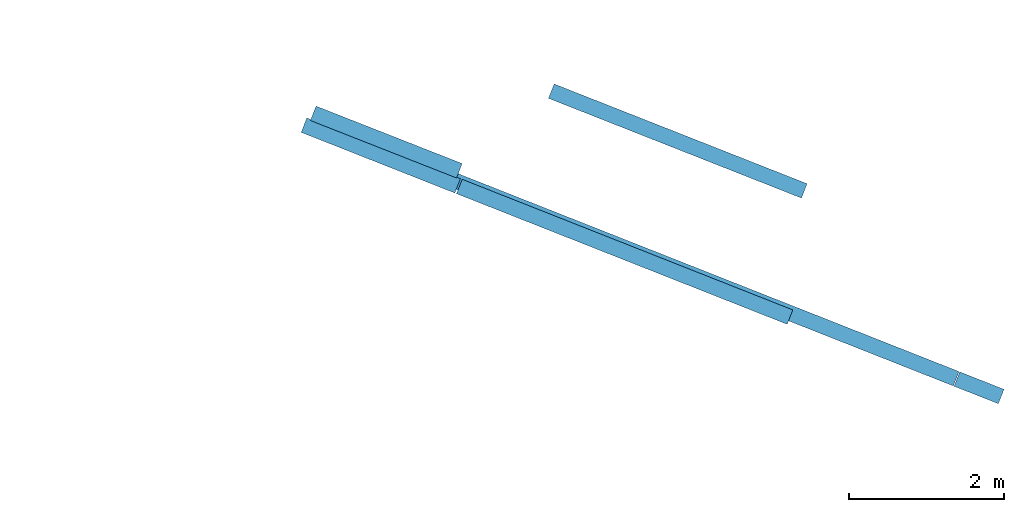
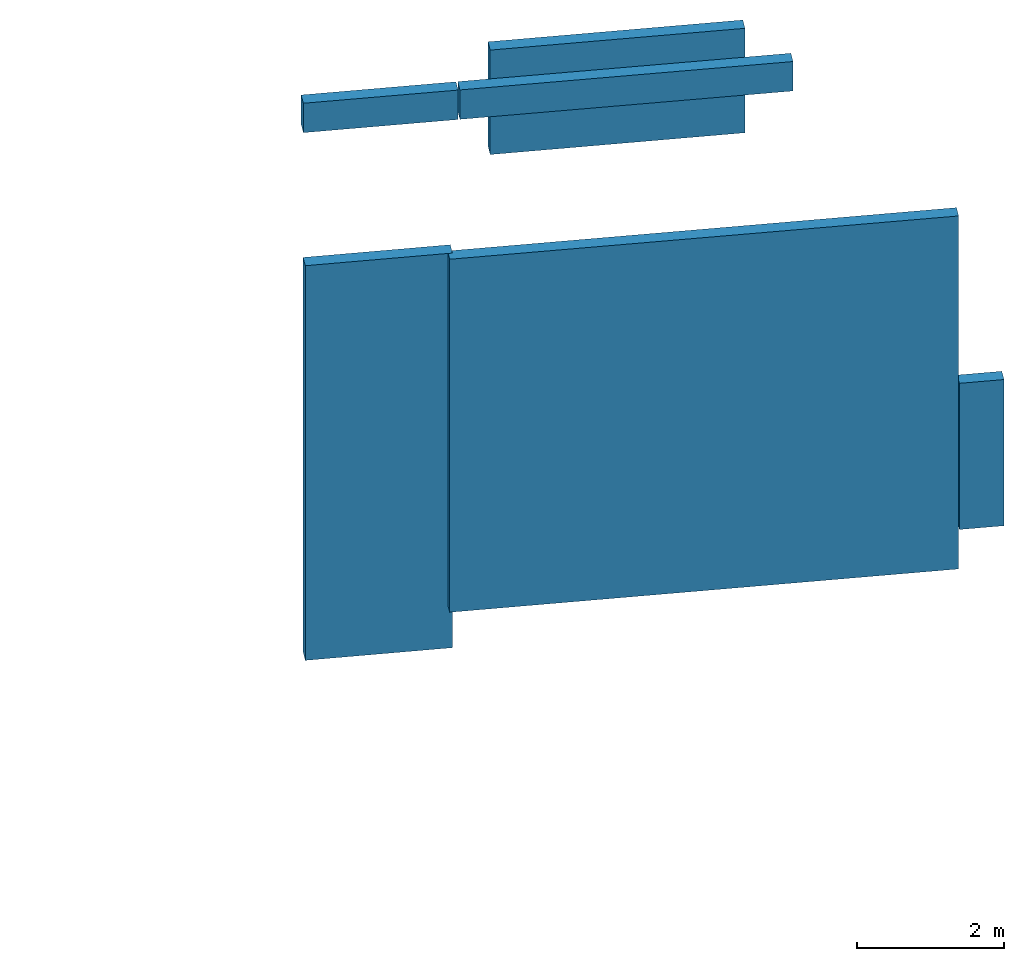
# One storey, part 26 of 27: 6 walls.
"""IFC2X3 building model written with IfcOpenShell, lengths in metres."""

from ifc_helpers import new_model, entity, si_unit, converted_unit, derived_unit, direction, frame, origin, place, context, subcontext, project, spatial, polyline, outline, extrude, material, layer, layer_set, layer_usage, type_object, element, save


model = new_model("IFC2X3")

# Units and contexts
model_context = context("Model", 3, precision=1e-05, world=origin(), true_north=direction((0.0, 1.0)))
body_context = subcontext(model_context, "Body", "Model", "MODEL_VIEW")
ifc_project = project(units=[si_unit("LENGTHUNIT", "METRE"), si_unit("AREAUNIT", "SQUARE_METRE"), si_unit("VOLUMEUNIT", "CUBIC_METRE"), converted_unit("PLANEANGLEUNIT", "DEGREE", entity("IfcRatioMeasure", 0.0174532925199433), si_unit("PLANEANGLEUNIT", "RADIAN"), dimensions=[0, 0, 0, 0, 0, 0, 0]), si_unit("MASSUNIT", "GRAM", prefix="KILO"), derived_unit("MASSDENSITYUNIT", [(si_unit("MASSUNIT", "GRAM", prefix="KILO"), 1), (si_unit("LENGTHUNIT", "METRE"), -3)]), derived_unit("MOMENTOFINERTIAUNIT", [(si_unit("LENGTHUNIT", "METRE"), 4)]), si_unit("TIMEUNIT", "SECOND"), si_unit("FREQUENCYUNIT", "HERTZ"), si_unit("THERMODYNAMICTEMPERATUREUNIT", "DEGREE_CELSIUS"), derived_unit("THERMALTRANSMITTANCEUNIT", [(si_unit("MASSUNIT", "GRAM", prefix="KILO"), 1), (si_unit("THERMODYNAMICTEMPERATUREUNIT", "KELVIN"), -1), (si_unit("TIMEUNIT", "SECOND"), -3)]), derived_unit("VOLUMETRICFLOWRATEUNIT", [(si_unit("LENGTHUNIT", "METRE"), 3), (si_unit("TIMEUNIT", "SECOND"), -1)]), si_unit("ELECTRICCURRENTUNIT", "AMPERE"), si_unit("ELECTRICVOLTAGEUNIT", "VOLT"), si_unit("POWERUNIT", "WATT"), si_unit("FORCEUNIT", "NEWTON", prefix="KILO"), si_unit("ILLUMINANCEUNIT", "LUX"), si_unit("LUMINOUSFLUXUNIT", "LUMEN"), si_unit("LUMINOUSINTENSITYUNIT", "CANDELA"), derived_unit("USERDEFINED", [(si_unit("MASSUNIT", "GRAM", prefix="KILO"), -1), (si_unit("LENGTHUNIT", "METRE"), -2), (si_unit("TIMEUNIT", "SECOND"), 3), (si_unit("LUMINOUSFLUXUNIT", "LUMEN"), 1)]), derived_unit("LINEARVELOCITYUNIT", [(si_unit("LENGTHUNIT", "METRE"), 1), (si_unit("TIMEUNIT", "SECOND"), -1)]), si_unit("PRESSUREUNIT", "PASCAL"), derived_unit("USERDEFINED", [(si_unit("LENGTHUNIT", "METRE"), -2), (si_unit("MASSUNIT", "GRAM", prefix="KILO"), 1), (si_unit("TIMEUNIT", "SECOND"), -2)]), derived_unit("LINEARFORCEUNIT", [(si_unit("MASSUNIT", "GRAM", prefix="KILO"), 1), (si_unit("LENGTHUNIT", "METRE"), 1), (si_unit("TIMEUNIT", "SECOND"), -2), (si_unit("LENGTHUNIT", "METRE"), -1)]), derived_unit("PLANARFORCEUNIT", [(si_unit("MASSUNIT", "GRAM", prefix="KILO"), 1), (si_unit("LENGTHUNIT", "METRE"), 1), (si_unit("TIMEUNIT", "SECOND"), -2), (si_unit("LENGTHUNIT", "METRE"), -2)])], contexts=[model_context])

# Site, building, storey
placement_1 = place(None, origin())
site = spatial("IfcSite", under=ifc_project, at=placement_1, CompositionType="ELEMENT")
building = spatial("IfcBuilding", under=site, at=placement_1, CompositionType="ELEMENT")
storey_placement = place(placement_1, frame((0.0, 0.0, -61.043098449707)))
storey = spatial("IfcBuildingStorey", under=building, at=storey_placement, Name="level_-61.043098", CompositionType="ELEMENT", Elevation=-61.043098449707)

# Walls
ifc_material = material(Name="Default wall")
ifc_layer = layer(ifc_material, 0.2)
ifc_layer_set = layer_set([ifc_layer], Name="wall_thickness_0.2000")
ifc_layer_usage = layer_usage(ifc_layer_set, "AXIS2", "POSITIVE", -0.1)
wall_type = type_object("IfcWallType", Name="wall_thickness_0.2000", PredefinedType="STANDARD", material=ifc_layer_set)
placement_2 = place(placement_1, frame((0.0, 0.0, -59.5395584106445)))
wall_1_placement = place(placement_2, frame((56.8783227039985, 36.7668436843472, 0.0), z_axis=(0.0, 0.0, 1.0), x_axis=(0.930651507982765, -0.365906778687421, 0.0)))
element("IfcWallStandardCase", 1, at=wall_1_placement, inside=storey, type_object=wall_type, material=ifc_layer_usage, Name="Wall:305", ObjectType="Wall", context=body_context, shape_type="SweptSolid", body=[
    extrude(outline(polyline([(2.02999852812922, -0.1), (2.02999852812922, 0.1), (0.0, 0.1), (0.0, -0.1), (2.02999852812922, -0.1)])), origin(), (0.0, 0.0, 1.0), 6.57270812988281),
])
placement_3 = place(placement_1, frame((0.0, 0.0, -52.3671607971191)))
wall_2_placement = place(placement_3, frame((59.9564630441519, 37.0532822352019, 0.0), z_axis=(0.0, 0.0, 1.0), x_axis=(0.930275658870785, -0.366861279658303, 0.0)))
element("IfcWallStandardCase", 2, at=wall_2_placement, inside=storey, type_object=wall_type, material=ifc_layer_usage, Name="Wall:431", ObjectType="Wall", context=body_context, shape_type="SweptSolid", body=[
    extrude(outline(polyline([(3.51499741312486, -0.1), (3.51499741312486, 0.1), (0.0, 0.1), (0.0, -0.1), (3.51499741312486, -0.1)])), origin(), (0.0, 0.0, 1.0), 1.73999786376953),
])
placement_4 = place(placement_1, frame((0.0, 0.0, -50.6165657043457)))
wall_3_placement = place(placement_4, frame((58.7679277635918, 35.8201814371842, 0.0), z_axis=(0.0, 0.0, 1.0), x_axis=(0.930084352284685, -0.367346018945594, 0.0)))
element("IfcWallStandardCase", 3, at=wall_3_placement, inside=storey, type_object=wall_type, material=ifc_layer_usage, Name="Wall:1019", ObjectType="Wall", context=body_context, shape_type="SweptSolid", body=[
    extrude(outline(polyline([(4.59499725577427, -0.1), (4.59499725577427, 0.1), (0.0, 0.1), (0.0, -0.1), (4.59499725577427, -0.1)])), origin(), (0.0, 0.0, 1.0), 0.490001678466797),
])
placement_5 = place(placement_1, frame((0.0, 0.0, -50.6165657043457)))
wall_4_placement = place(placement_5, frame((56.7589441515312, 36.6136460978287, 0.0), z_axis=(0.0, 0.0, 1.0), x_axis=(0.930084467616512, -0.367345726936505, 0.0)))
element("IfcWallStandardCase", 4, at=wall_4_placement, inside=storey, type_object=wall_type, material=ifc_layer_usage, Name="Wall:1020", ObjectType="Wall", context=body_context, shape_type="SweptSolid", body=[
    extrude(outline(polyline([(2.1349987949138, -0.1), (2.1349987949138, 0.1), (0.0, 0.1), (0.0, -0.1), (2.1349987949138, -0.1)])), origin(), (0.0, 0.0, 1.0), 0.490001678466797),
])
placement_6 = place(placement_1, frame((0.0, 0.0, -58.1907234191895)))
wall_5_placement = place(placement_6, frame((65.1994448646404, 33.3315666696196, 0.0), z_axis=(0.0, 0.0, 1.0), x_axis=(0.930030294601176, -0.367482858272397, 0.0)))
element("IfcWallStandardCase", 5, at=wall_5_placement, inside=storey, type_object=wall_type, material=ifc_layer_usage, Name="Wall:1096", ObjectType="Wall", context=body_context, shape_type="SweptSolid", body=[
    extrude(outline(polyline([(0.61499940586189, -0.1), (0.61499940586189, 0.1), (0.0, 0.1), (0.0, -0.1), (0.61499940586189, -0.1)])), origin(), (0.0, 0.0, 1.0), 2.43500137329102),
])
placement_7 = place(placement_1, frame((0.0, 0.0, -58.8460121154785)))
wall_6_placement = place(placement_7, frame((58.6613284095622, 35.9149559518461, 0.0), z_axis=(0.0, 0.0, 1.0), x_axis=(0.930031041480122, -0.367480968056035, 0.0)))
element("IfcWallStandardCase", 6, at=wall_6_placement, inside=storey, type_object=wall_type, material=ifc_layer_usage, Name="Wall:1109", ObjectType="Wall", context=body_context, shape_type="SweptSolid", body=[
    extrude(outline(polyline([(7.01999818495744, -0.1), (7.01999818495744, 0.1), (0.0, 0.1), (0.0, -0.1), (7.01999818495744, -0.1)])), origin(), (0.0, 0.0, 1.0), 5.8791618347168),
])

save(model, "model.ifc")
